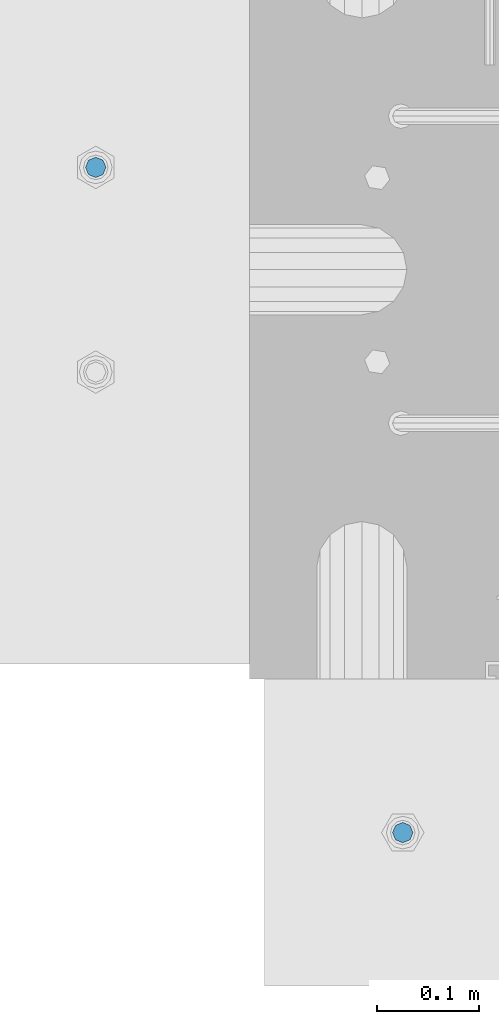
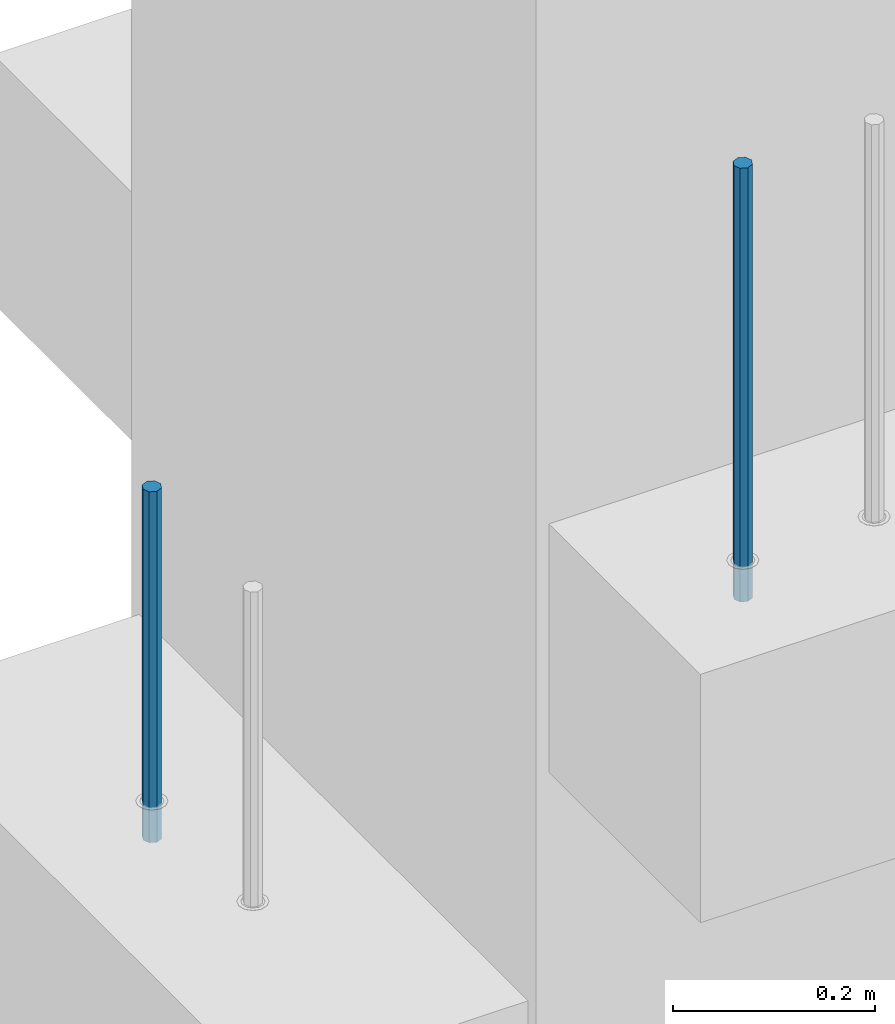
# One storey, part 12 of 41: 2 beams, 1 element without a shape of its own.
"""IFC2X3 building model written with IfcOpenShell, lengths in millimetres."""

import ifcopenshell
import ifcopenshell.guid

model = None  # the IFC model being written
_history = None  # IfcOwnerHistory: only IFC2X3 demands one
_inside = {}  # id of a spatial element -> (the spatial element, [elements in it])
_under = {}  # id of a project, library or spatial element -> (it, [spatial elements below it])
_declared = {}  # id of a project -> (the project, [libraries it declares])
_typed = {}  # id of a type object -> (the type object, [elements of that type])
_made_of = {}  # id of a material, layer set ... -> (it, [elements and type objects made of it])


def new_model(schema):
    """Start an empty IFC model of exactly this schema.

    Asked for "IFC4X3", IfcOpenShell would pick the latest addendum, in which some entities
    have other attributes; the version numbers below select the first issue.
    IFC2X3 requires an IfcOwnerHistory on every rooted entity: one is made here for all.
    """
    global model, _history
    if schema == "IFC4X3":
        model = ifcopenshell.file(schema_version=(4, 3, 0, 0))
    else:
        model = ifcopenshell.file(schema=schema)
    _inside.clear()
    _under.clear()
    _declared.clear()
    _typed.clear()
    _made_of.clear()
    _history = None
    if model.schema == "IFC2X3":
        org = make("IfcOrganization", Name="unknown")
        user = make(
            "IfcPersonAndOrganization",
            ThePerson=make("IfcPerson", FamilyName="unknown"),
            TheOrganization=org,
        )
        app = make(
            "IfcApplication",
            ApplicationDeveloper=org,
            Version="unknown",
            ApplicationFullName="unknown",
            ApplicationIdentifier="unknown",
        )
        _history = make(
            "IfcOwnerHistory",
            OwningUser=user,
            OwningApplication=app,
            ChangeAction="ADDED",
            CreationDate=0,
        )
    return model


def make(cls, **values):
    """One entity of the class cls with the attributes given. An attribute that is None is left unset."""
    return model.create_entity(
        cls, **{name: value for name, value in values.items() if value is not None}
    )


def rooted(cls, **values):
    """An entity with a GlobalId (a new one), such as an element, a storey or a relation."""
    return make(cls, GlobalId=ifcopenshell.guid.new(), OwnerHistory=_history, **values)


def si_unit(unit_type, name, prefix=None):
    """IfcSIUnit, for example si_unit("LENGTHUNIT", "METRE", prefix="MILLI")."""
    return make("IfcSIUnit", UnitType=unit_type, Prefix=prefix, Name=name)


def assignment(units):
    """IfcUnitAssignment: the units of a project."""
    return None if units is None else make("IfcUnitAssignment", Units=units)


def point(xyz):
    """IfcCartesianPoint."""
    return None if xyz is None else make("IfcCartesianPoint", Coordinates=xyz)


def direction(xyz):
    """IfcDirection."""
    return None if xyz is None else make("IfcDirection", DirectionRatios=xyz)


def frame(location, z_axis=None, x_axis=None):
    """IfcAxis2Placement3D, a coordinate frame: its origin and axes. An axis left out is left unset."""
    return make(
        "IfcAxis2Placement3D",
        Location=point(location),
        Axis=direction(z_axis),
        RefDirection=direction(x_axis),
    )


def origin_with_axes():
    """The frame at (0, 0, 0) with the z axis (0, 0, 1) and the x axis (1, 0, 0) written out."""
    return frame((0.0, 0.0, 0.0), z_axis=(0.0, 0.0, 1.0), x_axis=(1.0, 0.0, 0.0))


def place(relative_to, where):
    """IfcLocalPlacement: puts the frame where relative to a parent placement (None: the world)."""
    return make(
        "IfcLocalPlacement", PlacementRelTo=relative_to, RelativePlacement=where
    )


def context(
    kind, dimensions, precision=None, world=None, true_north=None, identifier=None
):
    """IfcGeometricRepresentationContext, for example the 3D "Model" context."""
    return make(
        "IfcGeometricRepresentationContext",
        ContextIdentifier=identifier,
        ContextType=kind,
        CoordinateSpaceDimension=dimensions,
        Precision=precision,
        WorldCoordinateSystem=world,
        TrueNorth=true_north,
    )


def subcontext(parent, identifier, kind, view, scale=None):
    """IfcGeometricRepresentationSubContext, for example "Body" below "Model"."""
    return make(
        "IfcGeometricRepresentationSubContext",
        ContextIdentifier=identifier,
        ContextType=kind,
        ParentContext=parent,
        TargetScale=scale,
        TargetView=view,
    )


def project(units=None, contexts=None):
    """IfcProject with its units and contexts."""
    return rooted(
        "IfcProject",
        Name="project",
        RepresentationContexts=contexts,
        UnitsInContext=assignment(units),
    )


def spatial(cls, under=None, at=None, **own):
    """A site, building, storey or space (cls), placed at a placement, below another one or the project."""
    s = rooted(cls, ObjectPlacement=at, **own)
    if under is not None:
        _under.setdefault(under.id(), (under, []))[1].append(s)
    return s


def faces_of(points, faces, orient=None, outer=None):
    """IfcFace entities. A face is a list of loops; a loop is a list of indices into points, from 0.

    orient and outer hold one flag for each loop. By default every Orientation is true, the
    first loop of a face is its IfcFaceOuterBound and the others are IfcFaceBound.
    """
    made = []
    for i, loops in enumerate(faces):
        bounds = []
        for j, loop in enumerate(loops):
            is_outer = j == 0 if outer is None else outer[i][j]
            bounds.append(
                make(
                    "IfcFaceOuterBound" if is_outer else "IfcFaceBound",
                    Bound=make("IfcPolyLoop", Polygon=[points[k] for k in loop]),
                    Orientation=True if orient is None else orient[i][j],
                )
            )
        made.append(make("IfcFace", Bounds=bounds))
    return made


def faceted_brep(points, faces, orient=None, outer=None, voids=None):
    """IfcFacetedBrep: a solid bounded by flat faces; with voids (closed shells), ...WithVoids."""
    shared = [point(p) for p in points]
    hull = make("IfcClosedShell", CfsFaces=faces_of(shared, faces, orient, outer))
    if voids is None:
        return make("IfcFacetedBrep", Outer=hull)
    return make(
        "IfcFacetedBrepWithVoids",
        Outer=hull,
        Voids=[
            make(cls, CfsFaces=faces_of(shared, fs, o, b)) for cls, fs, o, b in voids
        ],
    )


def shape(context_of_items, identifier, shape_type, items):
    """IfcShapeRepresentation: the items that make up one representation, for example the "Body"."""
    return make(
        "IfcShapeRepresentation",
        ContextOfItems=context_of_items,
        RepresentationIdentifier=identifier,
        RepresentationType=shape_type,
        Items=items,
    )


def material(Name=None, Category=None):
    """IfcMaterial."""
    return make("IfcMaterial", Name=Name, Category=Category)


def made_of(thing, what):
    """Note that an element or type object is made of a material, layer set ...; save() writes the relation."""
    if what is not None:
        _made_of.setdefault(what.id(), (what, []))[1].append(thing)
    return thing


def type_object(cls, material=None, **own):
    """A type object (cls), such as IfcWallType, which elements share."""
    return made_of(rooted(cls, **own), material)


def element(
    cls,
    number,
    at=None,
    inside=None,
    cuts=None,
    type_object=None,
    material=None,
    context=None,
    identifier="Body",
    shape_type=None,
    held_by="IfcProductDefinitionShape",
    body=None,
    shapes=None,
    **own,
):
    """One element of the class cls, such as IfcWall. Its Tag is "e" and its number.

    at: its placement. inside: the storey or other place that contains it. cuts: it is an
    opening in that element (IfcRelVoidsElement). A single representation is given by context,
    identifier, shape_type and body (its items); several are given by shapes. held_by: the class
    of the entity that holds the representations. save() writes the other relations.
    """
    e = rooted(cls, Tag="e%d" % number, ObjectPlacement=at, **own)
    if body is not None:
        shapes = [shape(context, identifier, shape_type, body)]
    if shapes is not None:
        e.Representation = make(held_by, Representations=shapes)
    if inside is not None:
        _inside.setdefault(inside.id(), (inside, []))[1].append(e)
    if cuts is not None:
        rooted(
            "IfcRelVoidsElement", RelatingBuildingElement=cuts, RelatedOpeningElement=e
        )
    if type_object is not None:
        _typed.setdefault(type_object.id(), (type_object, []))[1].append(e)
    return made_of(e, material)


def aggregate(whole, parts):
    """IfcRelAggregates: a whole, such as a stair, and the parts it consists of."""
    return rooted("IfcRelAggregates", RelatingObject=whole, RelatedObjects=parts)


def save(model, path):
    """Write the relations noted so far, then the file.

    IfcRelAggregates (storeys below a building ...), IfcRelContainedInSpatialStructure (elements
    in a storey), IfcRelDefinesByType, IfcRelAssociatesMaterial and IfcRelDeclares: one each for
    every whole, place, type object, material and project.
    """
    for whole, parts in _under.values():
        aggregate(whole, parts)
    for where, things in _inside.values():
        rooted(
            "IfcRelContainedInSpatialStructure",
            RelatedElements=things,
            RelatingStructure=where,
        )
    for kind, things in _typed.values():
        rooted("IfcRelDefinesByType", RelatedObjects=things, RelatingType=kind)
    for what, things in _made_of.values():
        rooted("IfcRelAssociatesMaterial", RelatedObjects=things, RelatingMaterial=what)
    for by, libraries in _declared.values():
        rooted("IfcRelDeclares", RelatingContext=by, RelatedDefinitions=libraries)
    model.write(path)


model = new_model("IFC2X3")

# Units and contexts
model_context = context("Model", 3, precision=1e-05, world=origin_with_axes())
body_context = subcontext(model_context, "Body", "Model", "MODEL_VIEW")
ifc_project = project(units=[si_unit("LENGTHUNIT", "METRE", prefix="MILLI"), si_unit("AREAUNIT", "SQUARE_METRE"), si_unit("VOLUMEUNIT", "CUBIC_METRE"), si_unit("MASSUNIT", "GRAM", prefix="KILO"), si_unit("TIMEUNIT", "SECOND"), si_unit("PLANEANGLEUNIT", "RADIAN"), si_unit("SOLIDANGLEUNIT", "STERADIAN"), si_unit("THERMODYNAMICTEMPERATUREUNIT", "DEGREE_CELSIUS"), si_unit("LUMINOUSINTENSITYUNIT", "LUMEN")], contexts=[model_context])

# Site, building, storey
site_placement = place(None, frame((-177556.685383467, -198018.589999756, 1290.0), z_axis=(0.0, 0.0, 1.0), x_axis=(0.788225611989142, -0.615386370180835, 0.0)))
site = spatial("IfcSite", under=ifc_project, at=site_placement, CompositionType="ELEMENT")
building_placement = place(site_placement, origin_with_axes())
building = spatial("IfcBuilding", under=site, at=building_placement, Name="Undefined", CompositionType="ELEMENT")
storey_placement = place(building_placement, origin_with_axes())
storey = spatial("IfcBuildingStorey", under=building, at=storey_placement, Name="Undefined", CompositionType="ELEMENT", Elevation=0.0)

# Assembly, beams
assembly_placement = place(storey_placement, origin_with_axes())
assembly = element("IfcElementAssembly", 1, at=assembly_placement, inside=storey, AssemblyPlace="NOTDEFINED", PredefinedType="REINFORCEMENT_UNIT")
ifc_material = material(Name="STEEL/S235JR")
beam_type = type_object("IfcBeamType", PredefinedType="NOTDEFINED")
beam_1_placement = place(assembly_placement, frame((17739.6624293569, 265197.341079639, 5549.99999999999), z_axis=(-0.788225611989142, -0.615386370180835, 0.0), x_axis=(0.0, 0.0, -1.0)))
beam_1 = element("IfcBeam", 2, at=beam_1_placement, type_object=beam_type, material=ifc_material, context=body_context, shape_type="Brep", body=[
    faceted_brep([(4.88085788674653e-07, -10.0, -3.86498868465424e-08), (0.0, -7.07106819456385, -7.07106766643119), (424.0, -7.07106751357787, -7.07106759684393), (424.0, -9.99999970174395, 2.15019099414349e-07), (4.97872867461239e-11, -3.88578058618805e-15, -10.0), (424.0, 2.98285158351064e-07, -9.9999997849518), (0.0, 7.07106742914766, -7.0710676664894), (424.0, 7.07106811014819, -7.07106759675662), (4.88085788674653e-07, 10.0, -3.86498868465424e-08), (424.0, 10.0000002982561, 2.15106410905719e-07), (0.0, 7.07106742919132, 7.07106795720756), (424.0, 7.07106811011909, 7.07106802696944), (-4.97872867461239e-11, 0.0, 10.0), (424.0, 2.98256054520607e-07, 10.0000002150773), (0.0, -7.07106819453475, 7.07106795729487), (424.0, -7.07106751357787, 7.07106802688213)], [[[0, 1, 2, 3]], [[1, 4, 5, 2]], [[4, 6, 7, 5]], [[6, 8, 9, 7]], [[8, 10, 11, 9]], [[10, 12, 13, 11]], [[12, 14, 15, 13]], [[14, 0, 3, 15]], [[5, 7, 9, 11, 13, 15, 3, 2]], [[14, 12, 10, 8, 6, 4, 1, 0]]]),
])
beam_2_placement = place(assembly_placement, frame((18376.1312535663, 264869.610342897, 6229.99999999999), z_axis=(0.615386370178831, -0.788225611990706, 0.0), x_axis=(0.0, 0.0, -1.0)))
beam_2 = element("IfcBeam", 3, at=beam_2_placement, type_object=beam_type, material=ifc_material, context=body_context, shape_type="Brep", body=[
    faceted_brep([(4.88085788674653e-07, -10.0, -3.86498868465424e-08), (0.0, -7.07106819456385, -7.07106766643119), (524.0, -7.07106759562157, -7.07106811032281), (524.0, -9.99999978375854, -2.98430677503347e-07), (4.97872867461239e-11, -3.88578058618805e-15, -10.0), (524.0, 2.16212356463075e-07, -10.000000298518), (0.0, 7.07106742914766, -7.0710676664894), (524.0, 7.07106802810449, -7.07106811041012), (4.88085788674653e-07, 10.0, -3.86498868465424e-08), (524.0, 10.0000002162415, -2.98547092825174e-07), (0.0, 7.07106742919132, 7.07106795720756), (524.0, 7.0710680281336, 7.07106751331594), (-4.97872867461239e-11, 0.0, 10.0), (524.0, 2.16299667954445e-07, 9.99999970148201), (0.0, -7.07106819453475, 7.07106795729487), (524.0, -7.07106759559247, 7.07106751340325)], [[[0, 1, 2, 3]], [[1, 4, 5, 2]], [[4, 6, 7, 5]], [[6, 8, 9, 7]], [[8, 10, 11, 9]], [[10, 12, 13, 11]], [[12, 14, 15, 13]], [[14, 0, 3, 15]], [[5, 7, 9, 11, 13, 15, 3, 2]], [[14, 12, 10, 8, 6, 4, 1, 0]]]),
])
aggregate(assembly, [beam_1, beam_2])

save(model, "model.ifc")
